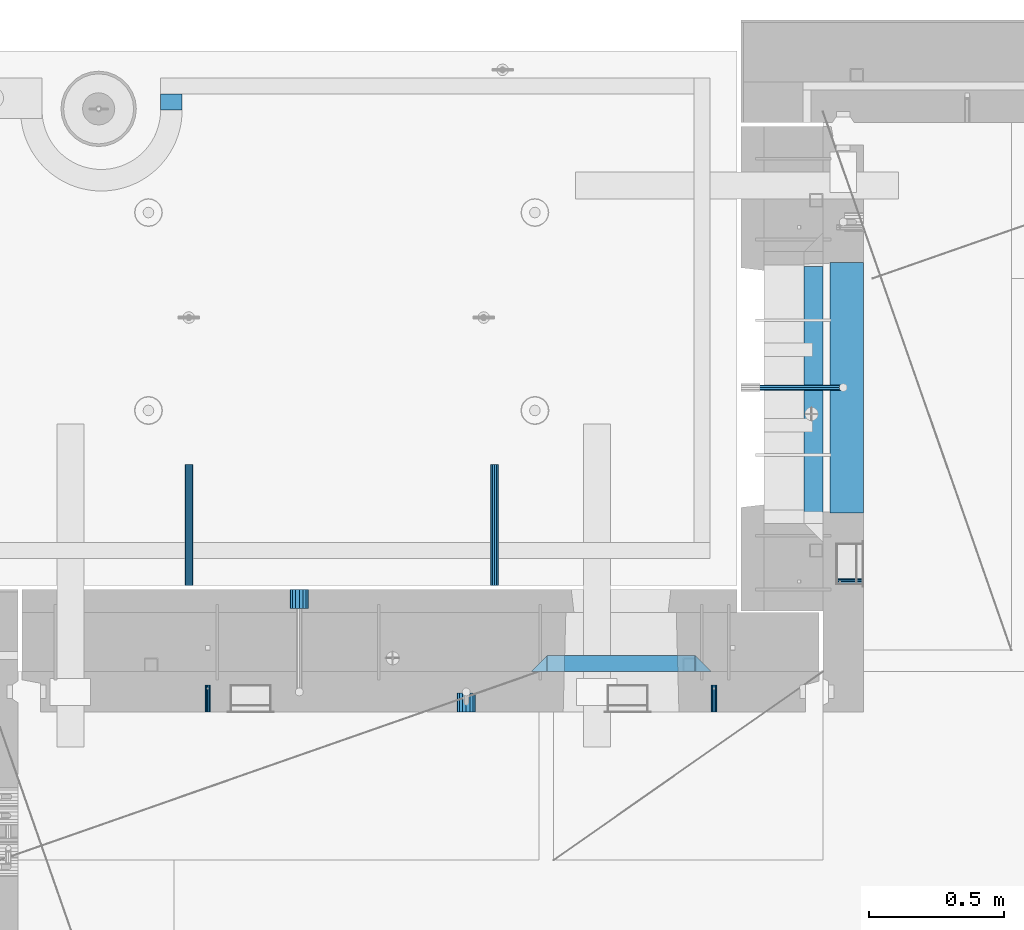
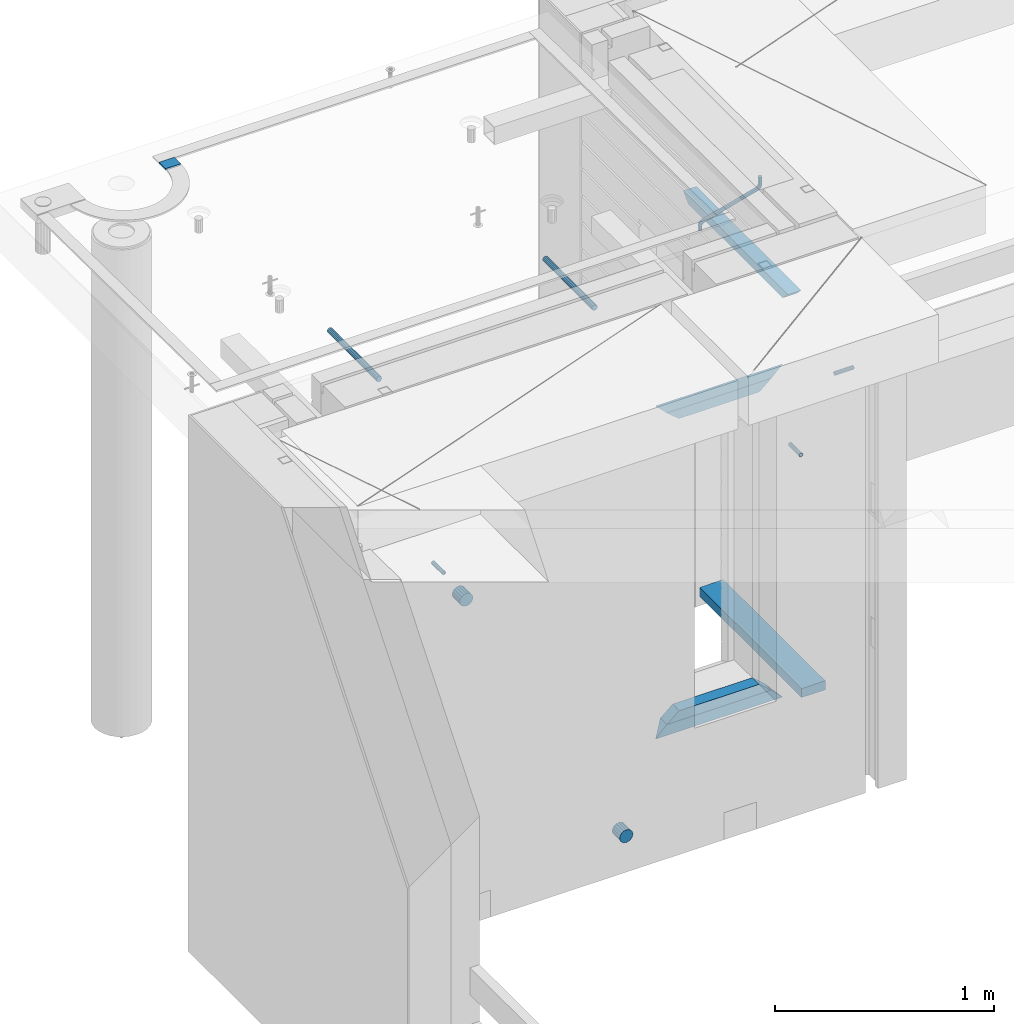
# One storey, part 157 of 349: 15 beams, 8 elements without a shape of their own.
"""IFC2X3 building model written with IfcOpenShell, lengths in millimetres."""

import ifcopenshell
import ifcopenshell.guid

model = None  # the IFC model being written
_history = None  # IfcOwnerHistory: only IFC2X3 demands one
_inside = {}  # id of a spatial element -> (the spatial element, [elements in it])
_under = {}  # id of a project, library or spatial element -> (it, [spatial elements below it])
_declared = {}  # id of a project -> (the project, [libraries it declares])
_typed = {}  # id of a type object -> (the type object, [elements of that type])
_made_of = {}  # id of a material, layer set ... -> (it, [elements and type objects made of it])


def new_model(schema):
    """Start an empty IFC model of exactly this schema.

    Asked for "IFC4X3", IfcOpenShell would pick the latest addendum, in which some entities
    have other attributes; the version numbers below select the first issue.
    IFC2X3 requires an IfcOwnerHistory on every rooted entity: one is made here for all.
    """
    global model, _history
    if schema == "IFC4X3":
        model = ifcopenshell.file(schema_version=(4, 3, 0, 0))
    else:
        model = ifcopenshell.file(schema=schema)
    _inside.clear()
    _under.clear()
    _declared.clear()
    _typed.clear()
    _made_of.clear()
    _history = None
    if model.schema == "IFC2X3":
        org = make("IfcOrganization", Name="unknown")
        user = make(
            "IfcPersonAndOrganization",
            ThePerson=make("IfcPerson", FamilyName="unknown"),
            TheOrganization=org,
        )
        app = make(
            "IfcApplication",
            ApplicationDeveloper=org,
            Version="unknown",
            ApplicationFullName="unknown",
            ApplicationIdentifier="unknown",
        )
        _history = make(
            "IfcOwnerHistory",
            OwningUser=user,
            OwningApplication=app,
            ChangeAction="ADDED",
            CreationDate=0,
        )
    return model


def make(cls, **values):
    """One entity of the class cls with the attributes given. An attribute that is None is left unset."""
    return model.create_entity(
        cls, **{name: value for name, value in values.items() if value is not None}
    )


def rooted(cls, **values):
    """An entity with a GlobalId (a new one), such as an element, a storey or a relation."""
    return make(cls, GlobalId=ifcopenshell.guid.new(), OwnerHistory=_history, **values)


def si_unit(unit_type, name, prefix=None):
    """IfcSIUnit, for example si_unit("LENGTHUNIT", "METRE", prefix="MILLI")."""
    return make("IfcSIUnit", UnitType=unit_type, Prefix=prefix, Name=name)


def assignment(units):
    """IfcUnitAssignment: the units of a project."""
    return None if units is None else make("IfcUnitAssignment", Units=units)


def point(xyz):
    """IfcCartesianPoint."""
    return None if xyz is None else make("IfcCartesianPoint", Coordinates=xyz)


def direction(xyz):
    """IfcDirection."""
    return None if xyz is None else make("IfcDirection", DirectionRatios=xyz)


def frame(location, z_axis=None, x_axis=None):
    """IfcAxis2Placement3D, a coordinate frame: its origin and axes. An axis left out is left unset."""
    return make(
        "IfcAxis2Placement3D",
        Location=point(location),
        Axis=direction(z_axis),
        RefDirection=direction(x_axis),
    )


def origin_with_axes():
    """The frame at (0, 0, 0) with the z axis (0, 0, 1) and the x axis (1, 0, 0) written out."""
    return frame((0.0, 0.0, 0.0), z_axis=(0.0, 0.0, 1.0), x_axis=(1.0, 0.0, 0.0))


def place(relative_to, where):
    """IfcLocalPlacement: puts the frame where relative to a parent placement (None: the world)."""
    return make(
        "IfcLocalPlacement", PlacementRelTo=relative_to, RelativePlacement=where
    )


def context(
    kind, dimensions, precision=None, world=None, true_north=None, identifier=None
):
    """IfcGeometricRepresentationContext, for example the 3D "Model" context."""
    return make(
        "IfcGeometricRepresentationContext",
        ContextIdentifier=identifier,
        ContextType=kind,
        CoordinateSpaceDimension=dimensions,
        Precision=precision,
        WorldCoordinateSystem=world,
        TrueNorth=true_north,
    )


def subcontext(parent, identifier, kind, view, scale=None):
    """IfcGeometricRepresentationSubContext, for example "Body" below "Model"."""
    return make(
        "IfcGeometricRepresentationSubContext",
        ContextIdentifier=identifier,
        ContextType=kind,
        ParentContext=parent,
        TargetScale=scale,
        TargetView=view,
    )


def project(units=None, contexts=None):
    """IfcProject with its units and contexts."""
    return rooted(
        "IfcProject",
        Name="project",
        RepresentationContexts=contexts,
        UnitsInContext=assignment(units),
    )


def spatial(cls, under=None, at=None, **own):
    """A site, building, storey or space (cls), placed at a placement, below another one or the project."""
    s = rooted(cls, ObjectPlacement=at, **own)
    if under is not None:
        _under.setdefault(under.id(), (under, []))[1].append(s)
    return s


def faces_of(points, faces, orient=None, outer=None):
    """IfcFace entities. A face is a list of loops; a loop is a list of indices into points, from 0.

    orient and outer hold one flag for each loop. By default every Orientation is true, the
    first loop of a face is its IfcFaceOuterBound and the others are IfcFaceBound.
    """
    made = []
    for i, loops in enumerate(faces):
        bounds = []
        for j, loop in enumerate(loops):
            is_outer = j == 0 if outer is None else outer[i][j]
            bounds.append(
                make(
                    "IfcFaceOuterBound" if is_outer else "IfcFaceBound",
                    Bound=make("IfcPolyLoop", Polygon=[points[k] for k in loop]),
                    Orientation=True if orient is None else orient[i][j],
                )
            )
        made.append(make("IfcFace", Bounds=bounds))
    return made


def faceted_brep(points, faces, orient=None, outer=None, voids=None):
    """IfcFacetedBrep: a solid bounded by flat faces; with voids (closed shells), ...WithVoids."""
    shared = [point(p) for p in points]
    hull = make("IfcClosedShell", CfsFaces=faces_of(shared, faces, orient, outer))
    if voids is None:
        return make("IfcFacetedBrep", Outer=hull)
    return make(
        "IfcFacetedBrepWithVoids",
        Outer=hull,
        Voids=[
            make(cls, CfsFaces=faces_of(shared, fs, o, b)) for cls, fs, o, b in voids
        ],
    )


def shape(context_of_items, identifier, shape_type, items):
    """IfcShapeRepresentation: the items that make up one representation, for example the "Body"."""
    return make(
        "IfcShapeRepresentation",
        ContextOfItems=context_of_items,
        RepresentationIdentifier=identifier,
        RepresentationType=shape_type,
        Items=items,
    )


def material(Name=None, Category=None):
    """IfcMaterial."""
    return make("IfcMaterial", Name=Name, Category=Category)


def made_of(thing, what):
    """Note that an element or type object is made of a material, layer set ...; save() writes the relation."""
    if what is not None:
        _made_of.setdefault(what.id(), (what, []))[1].append(thing)
    return thing


def type_object(cls, material=None, **own):
    """A type object (cls), such as IfcWallType, which elements share."""
    return made_of(rooted(cls, **own), material)


def element(
    cls,
    number,
    at=None,
    inside=None,
    cuts=None,
    type_object=None,
    material=None,
    context=None,
    identifier="Body",
    shape_type=None,
    held_by="IfcProductDefinitionShape",
    body=None,
    shapes=None,
    **own,
):
    """One element of the class cls, such as IfcWall. Its Tag is "e" and its number.

    at: its placement. inside: the storey or other place that contains it. cuts: it is an
    opening in that element (IfcRelVoidsElement). A single representation is given by context,
    identifier, shape_type and body (its items); several are given by shapes. held_by: the class
    of the entity that holds the representations. save() writes the other relations.
    """
    e = rooted(cls, Tag="e%d" % number, ObjectPlacement=at, **own)
    if body is not None:
        shapes = [shape(context, identifier, shape_type, body)]
    if shapes is not None:
        e.Representation = make(held_by, Representations=shapes)
    if inside is not None:
        _inside.setdefault(inside.id(), (inside, []))[1].append(e)
    if cuts is not None:
        rooted(
            "IfcRelVoidsElement", RelatingBuildingElement=cuts, RelatedOpeningElement=e
        )
    if type_object is not None:
        _typed.setdefault(type_object.id(), (type_object, []))[1].append(e)
    return made_of(e, material)


def aggregate(whole, parts):
    """IfcRelAggregates: a whole, such as a stair, and the parts it consists of."""
    return rooted("IfcRelAggregates", RelatingObject=whole, RelatedObjects=parts)


def save(model, path):
    """Write the relations noted so far, then the file.

    IfcRelAggregates (storeys below a building ...), IfcRelContainedInSpatialStructure (elements
    in a storey), IfcRelDefinesByType, IfcRelAssociatesMaterial and IfcRelDeclares: one each for
    every whole, place, type object, material and project.
    """
    for whole, parts in _under.values():
        aggregate(whole, parts)
    for where, things in _inside.values():
        rooted(
            "IfcRelContainedInSpatialStructure",
            RelatedElements=things,
            RelatingStructure=where,
        )
    for kind, things in _typed.values():
        rooted("IfcRelDefinesByType", RelatedObjects=things, RelatingType=kind)
    for what, things in _made_of.values():
        rooted("IfcRelAssociatesMaterial", RelatedObjects=things, RelatingMaterial=what)
    for by, libraries in _declared.values():
        rooted("IfcRelDeclares", RelatingContext=by, RelatedDefinitions=libraries)
    model.write(path)


model = new_model("IFC2X3")

# Units and contexts
model_context = context("Model", 3, precision=1e-05, world=origin_with_axes())
body_context = subcontext(model_context, "Body", "Model", "MODEL_VIEW")
ifc_project = project(units=[si_unit("LENGTHUNIT", "METRE", prefix="MILLI"), si_unit("AREAUNIT", "SQUARE_METRE"), si_unit("VOLUMEUNIT", "CUBIC_METRE"), si_unit("MASSUNIT", "GRAM", prefix="KILO"), si_unit("TIMEUNIT", "SECOND"), si_unit("PLANEANGLEUNIT", "RADIAN"), si_unit("SOLIDANGLEUNIT", "STERADIAN"), si_unit("THERMODYNAMICTEMPERATUREUNIT", "DEGREE_CELSIUS"), si_unit("LUMINOUSINTENSITYUNIT", "LUMEN")], contexts=[model_context])

# Site, building, storey
site_placement = place(None, origin_with_axes())
site = spatial("IfcSite", under=ifc_project, at=site_placement, CompositionType="ELEMENT")
building_placement = place(site_placement, origin_with_axes())
building = spatial("IfcBuilding", under=site, at=building_placement, CompositionType="ELEMENT")
storey_placement = place(building_placement, origin_with_axes())
storey = spatial("IfcBuildingStorey", under=building, at=storey_placement, Name="4", CompositionType="ELEMENT", Elevation=0.0)

# Assembly, beam
assembly_1_placement = place(storey_placement, origin_with_axes())
assembly_1 = element("IfcElementAssembly", 1, at=assembly_1_placement, inside=storey, AssemblyPlace="NOTDEFINED", PredefinedType="REINFORCEMENT_UNIT")
ifc_material_1 = material(Name="CONCRETE/C25/30")
beam_type_1 = type_object("IfcBeamType", PredefinedType="NOTDEFINED")
beam_1_placement = place(assembly_1_placement, frame((10955.0, 22139.9998901814, 93080.0), z_axis=(0.0, 0.0, -1.0), x_axis=(0.0, -1.0, 0.0)))
beam_1 = element("IfcBeam", 2, at=beam_1_placement, type_object=beam_type_1, material=ifc_material_1, Name="SK", context=body_context, shape_type="Brep", body=[
    faceted_brep([(100.641025641038, 35.0, 20.6410256410309), (55.0, 35.0, -25.0), (55.0, -35.0, -25.0), (98.8461538461561, -35.0, 18.8461538461561), (966.153464684117, -35.0, 18.8461538461561), (964.358592889246, 35.0, 20.6410256410309), (1009.99961853027, 35.0, -25.0), (1009.99961853027, -35.0, -25.0)], [[[0, 1, 2, 3]], [[0, 3, 4, 5]], [[1, 0, 5, 6]], [[2, 1, 6, 7]], [[3, 2, 7, 4]], [[4, 7, 6, 5]]]),
])

# Assemblies, beams
assembly_2_placement = place(storey_placement, origin_with_axes())
assembly_2 = element("IfcElementAssembly", 3, at=assembly_2_placement, inside=storey, AssemblyPlace="NOTDEFINED", PredefinedType="REINFORCEMENT_UNIT")
assembly_3_placement = place(assembly_2_placement, origin_with_axes())
assembly_3 = element("IfcElementAssembly", 4, at=assembly_3_placement, Name="Steel Assembly", AssemblyPlace="NOTDEFINED", PredefinedType="RIGID_FRAME")
ifc_material_2 = material(Name="STEEL/Steel_Undefined")
beam_type_2 = type_object("IfcBeamType", PredefinedType="NOTDEFINED")
beam_2_placement = place(assembly_3_placement, frame((8704.99903261663, 20429.9951872276, 92755.0), z_axis=(1.0, 0.0, 0.0), x_axis=(0.0, 1.0, 0.0)))
beam_2 = element("IfcBeam", 5, at=beam_2_placement, type_object=beam_type_2, material=ifc_material_2, Name="M16", context=body_context, shape_type="Brep", body=[
    faceted_brep([(0.0, -8.49999999999272, -1.45519152283669e-11), (0.0, -7.36121593215648, 4.24999999998545), (100.000000000262, -7.36121593215648, 4.24999999998545), (100.000000000262, -8.49999999999272, -1.45519152283669e-11), (0.0, -4.24999999998545, 7.36121593216376), (100.000000000262, -4.24999999998545, 7.36121593216376), (0.0, 1.45519152283669e-11, 8.49999999998545), (100.000000000262, 1.45519152283669e-11, 8.49999999998545), (0.0, 4.25000000001455, 7.36121593216376), (100.000000000262, 4.25000000001455, 7.36121593216376), (0.0, 7.36121593217104, 4.24999999998545), (100.000000000262, 7.36121593217104, 4.24999999998545), (0.0, 8.50000000000728, 0.0), (100.000000000262, 8.50000000000728, 0.0), (0.0, 7.36121593217104, -4.25000000001455), (100.000000000262, 7.36121593217104, -4.25000000001455), (0.0, 4.25000000000728, -7.36121593219286), (100.000000000262, 4.25000000000728, -7.36121593219286), (0.0, 7.27595761418343e-12, -8.5), (100.000000000262, 7.27595761418343e-12, -8.5), (0.0, -4.24999999999272, -7.36121593217831), (100.000000000262, -4.24999999999272, -7.36121593217831), (0.0, -7.36121593215648, -4.25), (100.000000000262, -7.36121593215648, -4.25), (0.0, -10.4999999999927, -1.45519152283669e-11), (0.0, -9.09326673972828, -5.25000000001455), (100.000000000262, -9.09326673972828, -5.25000000001455), (100.000000000262, -10.4999999999927, -1.45519152283669e-11), (0.0, -5.24999999998545, -9.09326673974283), (100.000000000262, -5.24999999998545, -9.09326673974283), (0.0, 7.27595761418343e-12, -10.5), (100.000000000262, 7.27595761418343e-12, -10.5), (0.0, 5.25000000001455, -9.09326673975738), (100.000000000262, 5.25000000001455, -9.09326673975738), (0.0, 9.09326673975011, -5.25000000001455), (100.000000000262, 9.09326673975011, -5.25000000001455), (0.0, 10.5000000000073, -1.45519152283669e-11), (100.000000000262, 10.5000000000073, -1.45519152283669e-11), (0.0, 9.09326673975011, 5.25), (100.000000000262, 9.09326673975011, 5.25), (0.0, 5.25000000000728, 9.09326673972828), (100.000000000262, 5.25000000000728, 9.09326673972828), (0.0, 1.45519152283669e-11, 10.4999999999854), (100.000000000262, 1.45519152283669e-11, 10.4999999999854), (0.0, -5.24999999999272, 9.09326673972828), (100.000000000262, -5.24999999999272, 9.09326673972828), (0.0, -9.09326673972828, 5.24999999998545), (100.000000000262, -9.09326673972828, 5.24999999998545)], [[[0, 1, 2, 3]], [[1, 4, 5, 2]], [[4, 6, 7, 5]], [[6, 8, 9, 7]], [[8, 10, 11, 9]], [[10, 12, 13, 11]], [[12, 14, 15, 13]], [[14, 16, 17, 15]], [[16, 18, 19, 17]], [[18, 20, 21, 19]], [[20, 22, 23, 21]], [[22, 0, 3, 23]], [[24, 25, 26, 27]], [[25, 28, 29, 26]], [[28, 30, 31, 29]], [[30, 32, 33, 31]], [[32, 34, 35, 33]], [[34, 36, 37, 35]], [[36, 38, 39, 37]], [[38, 40, 41, 39]], [[40, 42, 43, 41]], [[42, 44, 45, 43]], [[44, 46, 47, 45]], [[46, 24, 27, 47]], [[29, 31, 33, 35, 37, 39, 41, 43, 45, 47, 27, 26], [5, 7, 9, 11, 13, 15, 17, 19, 21, 23, 3, 2]], [[46, 44, 42, 40, 38, 36, 34, 32, 30, 28, 25, 24], [22, 20, 18, 16, 14, 12, 10, 8, 6, 4, 1, 0]]]),
])
aggregate(assembly_3, [beam_2])
assembly_4_placement = place(assembly_2_placement, origin_with_axes())
assembly_4 = element("IfcElementAssembly", 6, at=assembly_4_placement, Name="Steel Assembly", AssemblyPlace="NOTDEFINED", PredefinedType="RIGID_FRAME")
beam_3_placement = place(assembly_4_placement, frame((10584.9990326166, 20429.9951872276, 92755.0), z_axis=(1.0, 0.0, 0.0), x_axis=(0.0, 1.0, 0.0)))
beam_3 = element("IfcBeam", 7, at=beam_3_placement, type_object=beam_type_2, material=ifc_material_2, Name="M16", context=body_context, shape_type="Brep", body=[
    faceted_brep([(0.0, -8.49999999999272, -1.45519152283669e-11), (0.0, -7.36121593215648, 4.24999999998545), (100.000000000262, -7.36121593215648, 4.24999999998545), (100.000000000262, -8.49999999999272, -1.45519152283669e-11), (0.0, -4.24999999998545, 7.36121593216376), (100.000000000262, -4.24999999998545, 7.36121593216376), (0.0, 1.45519152283669e-11, 8.49999999998545), (100.000000000262, 1.45519152283669e-11, 8.49999999998545), (0.0, 4.25000000001455, 7.36121593216376), (100.000000000262, 4.25000000001455, 7.36121593216376), (0.0, 7.36121593217104, 4.24999999998545), (100.000000000262, 7.36121593217104, 4.24999999998545), (0.0, 8.50000000000728, 0.0), (100.000000000262, 8.50000000000728, 0.0), (0.0, 7.36121593217104, -4.25000000001455), (100.000000000262, 7.36121593217104, -4.25000000001455), (0.0, 4.25000000000728, -7.36121593219286), (100.000000000262, 4.25000000000728, -7.36121593219286), (0.0, 7.27595761418343e-12, -8.5), (100.000000000262, 7.27595761418343e-12, -8.5), (0.0, -4.24999999999272, -7.36121593217831), (100.000000000262, -4.24999999999272, -7.36121593217831), (0.0, -7.36121593215648, -4.25), (100.000000000262, -7.36121593215648, -4.25), (0.0, -10.4999999999927, -1.45519152283669e-11), (0.0, -9.09326673972828, -5.25000000001455), (100.000000000262, -9.09326673972828, -5.25000000001455), (100.000000000262, -10.4999999999927, -1.45519152283669e-11), (0.0, -5.24999999998545, -9.09326673974283), (100.000000000262, -5.24999999998545, -9.09326673974283), (0.0, 7.27595761418343e-12, -10.5), (100.000000000262, 7.27595761418343e-12, -10.5), (0.0, 5.25000000001455, -9.09326673975738), (100.000000000262, 5.25000000001455, -9.09326673975738), (0.0, 9.09326673975011, -5.25000000001455), (100.000000000262, 9.09326673975011, -5.25000000001455), (0.0, 10.5000000000073, -1.45519152283669e-11), (100.000000000262, 10.5000000000073, -1.45519152283669e-11), (0.0, 9.09326673975011, 5.25), (100.000000000262, 9.09326673975011, 5.25), (0.0, 5.25000000000728, 9.09326673972828), (100.000000000262, 5.25000000000728, 9.09326673972828), (0.0, 1.45519152283669e-11, 10.4999999999854), (100.000000000262, 1.45519152283669e-11, 10.4999999999854), (0.0, -5.24999999999272, 9.09326673972828), (100.000000000262, -5.24999999999272, 9.09326673972828), (0.0, -9.09326673972828, 5.24999999998545), (100.000000000262, -9.09326673972828, 5.24999999998545)], [[[0, 1, 2, 3]], [[1, 4, 5, 2]], [[4, 6, 7, 5]], [[6, 8, 9, 7]], [[8, 10, 11, 9]], [[10, 12, 13, 11]], [[12, 14, 15, 13]], [[14, 16, 17, 15]], [[16, 18, 19, 17]], [[18, 20, 21, 19]], [[20, 22, 23, 21]], [[22, 0, 3, 23]], [[24, 25, 26, 27]], [[25, 28, 29, 26]], [[28, 30, 31, 29]], [[30, 32, 33, 31]], [[32, 34, 35, 33]], [[34, 36, 37, 35]], [[36, 38, 39, 37]], [[38, 40, 41, 39]], [[40, 42, 43, 41]], [[42, 44, 45, 43]], [[44, 46, 47, 45]], [[46, 24, 27, 47]], [[29, 31, 33, 35, 37, 39, 41, 43, 45, 47, 27, 26], [5, 7, 9, 11, 13, 15, 17, 19, 21, 23, 3, 2]], [[46, 44, 42, 40, 38, 36, 34, 32, 30, 28, 25, 24], [22, 20, 18, 16, 14, 12, 10, 8, 6, 4, 1, 0]]]),
])
aggregate(assembly_4, [beam_3])

# Assembly, beam
assembly_5_placement = place(assembly_1_placement, origin_with_axes())
assembly_5 = element("IfcElementAssembly", 8, at=assembly_5_placement, Name="Steel Assembly", AssemblyPlace="NOTDEFINED", PredefinedType="RIGID_FRAME")
beam_4_placement = place(assembly_5_placement, frame((11140.0, 20914.9954408996, 92755.0), z_axis=(0.0, -1.0, 0.0), x_axis=(-1.0, 3.00000001838171e-08, 0.0)))
beam_4 = element("IfcBeam", 9, at=beam_4_placement, type_object=beam_type_2, material=ifc_material_2, Name="M16", context=body_context, shape_type="Brep", body=[
    faceted_brep([(0.0, -8.49999999999272, -1.45519152283669e-11), (0.0, -7.36121593215648, 4.24999999998545), (100.000000000262, -7.36121593215648, 4.24999999998545), (100.000000000262, -8.49999999999272, -1.45519152283669e-11), (0.0, -4.24999999998545, 7.36121593216376), (100.000000000262, -4.24999999998545, 7.36121593216376), (0.0, 1.45519152283669e-11, 8.49999999998545), (100.000000000262, 1.45519152283669e-11, 8.49999999998545), (0.0, 4.25000000001455, 7.36121593216376), (100.000000000262, 4.25000000001455, 7.36121593216376), (0.0, 7.36121593217104, 4.24999999998545), (100.000000000262, 7.36121593217104, 4.24999999998545), (0.0, 8.50000000000728, 0.0), (100.000000000262, 8.50000000000728, 0.0), (0.0, 7.36121593217104, -4.25000000001455), (100.000000000262, 7.36121593217104, -4.25000000001455), (0.0, 4.25000000000728, -7.36121593219286), (100.000000000262, 4.25000000000728, -7.36121593219286), (0.0, 7.27595761418343e-12, -8.5), (100.000000000262, 7.27595761418343e-12, -8.5), (0.0, -4.24999999999272, -7.36121593217831), (100.000000000262, -4.24999999999272, -7.36121593217831), (0.0, -7.36121593215648, -4.25), (100.000000000262, -7.36121593215648, -4.25), (0.0, -10.4999999999927, -1.45519152283669e-11), (0.0, -9.09326673972828, -5.25000000001455), (100.000000000262, -9.09326673972828, -5.25000000001455), (100.000000000262, -10.4999999999927, -1.45519152283669e-11), (0.0, -5.24999999998545, -9.09326673974283), (100.000000000262, -5.24999999998545, -9.09326673974283), (0.0, 7.27595761418343e-12, -10.5), (100.000000000262, 7.27595761418343e-12, -10.5), (0.0, 5.25000000001455, -9.09326673975738), (100.000000000262, 5.25000000001455, -9.09326673975738), (0.0, 9.09326673975011, -5.25000000001455), (100.000000000262, 9.09326673975011, -5.25000000001455), (0.0, 10.5000000000073, -1.45519152283669e-11), (100.000000000262, 10.5000000000073, -1.45519152283669e-11), (0.0, 9.09326673975011, 5.25), (100.000000000262, 9.09326673975011, 5.25), (0.0, 5.25000000000728, 9.09326673972828), (100.000000000262, 5.25000000000728, 9.09326673972828), (0.0, 1.45519152283669e-11, 10.4999999999854), (100.000000000262, 1.45519152283669e-11, 10.4999999999854), (0.0, -5.24999999999272, 9.09326673972828), (100.000000000262, -5.24999999999272, 9.09326673972828), (0.0, -9.09326673972828, 5.24999999998545), (100.000000000262, -9.09326673972828, 5.24999999998545)], [[[0, 1, 2, 3]], [[1, 4, 5, 2]], [[4, 6, 7, 5]], [[6, 8, 9, 7]], [[8, 10, 11, 9]], [[10, 12, 13, 11]], [[12, 14, 15, 13]], [[14, 16, 17, 15]], [[16, 18, 19, 17]], [[18, 20, 21, 19]], [[20, 22, 23, 21]], [[22, 0, 3, 23]], [[24, 25, 26, 27]], [[25, 28, 29, 26]], [[28, 30, 31, 29]], [[30, 32, 33, 31]], [[32, 34, 35, 33]], [[34, 36, 37, 35]], [[36, 38, 39, 37]], [[38, 40, 41, 39]], [[40, 42, 43, 41]], [[42, 44, 45, 43]], [[44, 46, 47, 45]], [[46, 24, 27, 47]], [[29, 31, 33, 35, 37, 39, 41, 43, 45, 47, 27, 26], [5, 7, 9, 11, 13, 15, 17, 19, 21, 23, 3, 2]], [[46, 44, 42, 40, 38, 36, 34, 32, 30, 28, 25, 24], [22, 20, 18, 16, 14, 12, 10, 8, 6, 4, 1, 0]]]),
])
aggregate(assembly_5, [beam_4])

# Beam
ifc_material_3 = material()
beam_type_3 = type_object("IfcBeamType", Name="D20", PredefinedType="NOTDEFINED")
beam_5_placement = place(assembly_1_placement, frame((10747.93, 21634.9982799665, 93220.28), z_axis=(0.999209485784166, 0.00020572799995638, -0.0397537569914116), x_axis=(0.0397537569984931, -6.39999925638531e-08, 0.999209506962629)))
beam_5 = element("IfcBeam", 10, at=beam_5_placement, type_object=beam_type_3, material=ifc_material_3, Name="JM20", ObjectType="D20", context=body_context, shape_type="Brep", body=[
    faceted_brep([(0.0, -10.0, 0.0), (-4.19531716033816e-08, -7.07106781186667, -7.07106781187031), (26.3851730625611, -7.07106780271351, -7.07106779974674), (26.3851730660535, -9.99999999077045, 1.18243406177498e-08), (0.0, 0.0, -10.0), (26.3851730589668, 9.14587872102857e-09, -9.99999998788189), (4.196772351861e-08, 7.07106781186303, -7.07106781186667), (26.3851730576571, 7.07106782101255, -7.0710677997472), (0.0, 10.0, 0.0), (26.3851730593888, 10.0000000091495, 1.21176526590716e-08), (4.196772351861e-08, 7.07106781185939, 7.07106781185939), (26.3851730631723, 7.07106782101619, 7.07106782398387), (0.0, 0.0, 10.0), (26.3851730667375, 9.15315467864275e-09, 10.0000000121181), (-4.19531716033816e-08, -7.07106781187031, 7.07106781185939), (26.3851730680617, -7.07106780271351, 7.07106782398296), (38.6387990555377, 0.00053833780111745, -7.38336449283906), (37.4430586178205, -7.07058200552274, -4.70977034770021), (34.5550974405633, -9.99964106806146, 1.74460312923975), (31.6666440137633, -7.07083577596131, 8.19887149183023), (30.4697151806322, 0.000179452214069897, 10.8722118684241), (31.6654556183639, 7.07129979554884, 8.19861772327886), (34.5534167956066, 10.0003588580803, 1.74424424634026), (37.4418702223775, 7.07155356597286, -4.71002411625204), (46.5698109210789, 7.07292605872499, 1.96124086770624), (48.7548734831362, 0.00205940803425619, 0.0100898832683924), (41.2967727296491, 10.0013728005906, 6.67270684289633), (36.0246331664675, 7.07195524891722, 11.3845749391899), (33.8417400848848, 0.000686475628754124, 13.3366967298962), (36.0268026468402, -7.07018017507653, 11.385545745416), (41.2998408382991, -9.99862691692761, 6.67407977023777), (46.5719804015243, -7.06920936526149, 1.96221167398289), (52.1766955363273, 7.07494587836845, 11.77897587077), (54.9687243336812, 0.00429788071051007, 10.8906314292522), (45.4389138642146, 10.0028649622, 13.9256551011317), (38.7022804405424, 7.07291984242329, 16.0731735411446), (35.9130237601494, 0.00143263318750542, 16.9635440140905), (38.7050525575032, -7.06921536447044, 16.0751995724927), (45.4428342298197, -9.99713444846202, 13.9285203429881), (52.1794676532882, -7.06718932852891, 11.7810019021831), (142.166420299589, -7.00909836739083, 294.143799597011), (135.429786872017, -9.93904348683645, 296.291318034092), (144.955676979953, 0.0623888418631395, 293.253429124143), (142.163648182657, 7.13303683951744, 294.141773565681), (135.425866510661, 10.0609559233271, 296.288452795829), (128.689233087061, 7.13101080351771, 298.435971235634), (125.899976406712, 0.0595235942673753, 299.326341708503), (128.692005203993, -7.01112440339057, 298.437997266966), (147.068569920637, 0.0631443010061048, 296.926548661886), (144.897857494318, -7.00812174957537, 298.892215917644), (139.655137467547, -9.93753272500544, 303.636800386314), (134.411524128242, -7.00907940566321, 308.380988833921), (132.238655054738, 0.0617899707685865, 310.345700010335), (134.409367481101, 7.13305602133914, 308.38003275464), (139.652087507944, 10.0624669967765, 303.63544828606), (144.895700847192, 7.13401367743427, 298.891259838389), (149.349355837621, 7.13466950711154, 302.082919188319), (150.512901837996, 0.0636515012993186, 299.394888529177), (146.541460642286, 10.0634815017911, 308.572636332), (143.734043175544, 7.13442914049301, 315.062451673432), (142.571650514263, 0.0633115715718304, 317.750719402909), (143.735196514695, -7.0077064342513, 315.062688743805), (146.543091710148, -9.93651842893087, 308.572971600169), (149.350509176773, -7.0074660676255, 302.083156258706), (154.724909358454, 7.13488656737172, 303.143653317829), (154.670204234542, 0.063819369621342, 300.215230568659), (154.856921558763, 10.0638172729959, 310.213489346082), (154.988909878753, 7.13488360238989, 317.283324591871), (155.043557350815, 0.0638151764978829, 320.211745451903), (154.988852227005, -7.00725202125614, 317.28332270274), (154.856840031658, -9.93618272723688, 310.213486674455), (154.724851706691, -7.00724905626703, 303.143651428684), (199.544700311235, -7.00743165723543, 302.30682413155), (199.676688632229, -9.93636532781238, 309.37665937721), (199.490052838737, 0.0636367686238373, 299.378403271518), (199.544757962984, 7.13470396637786, 302.306826020583), (199.676770164122, 10.0636346720203, 309.376662048705), (199.808758485131, 7.13470100144696, 316.446497294365), (199.863405957614, 0.0636325755804137, 319.374918154397), (199.808700833368, -7.00743462216269, 316.446495405334)], [[[0, 1, 2, 3]], [[1, 4, 5, 2]], [[4, 6, 7, 5]], [[6, 8, 9, 7]], [[8, 10, 11, 9]], [[10, 12, 13, 11]], [[12, 14, 15, 13]], [[14, 0, 3, 15]], [[14, 12, 10, 8, 6, 4, 1, 0]], [[2, 5, 16, 17]], [[3, 2, 17, 18]], [[15, 3, 18, 19]], [[13, 15, 19, 20]], [[11, 13, 20, 21]], [[9, 11, 21, 22]], [[7, 9, 22, 23]], [[5, 7, 23, 16]], [[23, 24, 25, 16]], [[22, 26, 24, 23]], [[21, 27, 26, 22]], [[20, 28, 27, 21]], [[19, 29, 28, 20]], [[18, 30, 29, 19]], [[17, 31, 30, 18]], [[16, 25, 31, 17]], [[24, 32, 33, 25]], [[26, 34, 32, 24]], [[27, 35, 34, 26]], [[28, 36, 35, 27]], [[29, 37, 36, 28]], [[30, 38, 37, 29]], [[31, 39, 38, 30]], [[25, 33, 39, 31]], [[38, 39, 40, 41]], [[39, 33, 42, 40]], [[33, 32, 43, 42]], [[32, 34, 44, 43]], [[34, 35, 45, 44]], [[35, 36, 46, 45]], [[36, 37, 47, 46]], [[37, 38, 41, 47]], [[40, 42, 48, 49]], [[41, 40, 49, 50]], [[47, 41, 50, 51]], [[46, 47, 51, 52]], [[45, 46, 52, 53]], [[44, 45, 53, 54]], [[43, 44, 54, 55]], [[42, 43, 55, 48]], [[55, 56, 57, 48]], [[54, 58, 56, 55]], [[53, 59, 58, 54]], [[52, 60, 59, 53]], [[51, 61, 60, 52]], [[50, 62, 61, 51]], [[49, 63, 62, 50]], [[48, 57, 63, 49]], [[56, 64, 65, 57]], [[58, 66, 64, 56]], [[59, 67, 66, 58]], [[60, 68, 67, 59]], [[61, 69, 68, 60]], [[62, 70, 69, 61]], [[63, 71, 70, 62]], [[57, 65, 71, 63]], [[70, 71, 72, 73]], [[71, 65, 74, 72]], [[65, 64, 75, 74]], [[64, 66, 76, 75]], [[66, 67, 77, 76]], [[67, 68, 78, 77]], [[68, 69, 79, 78]], [[69, 70, 73, 79]], [[74, 75, 76, 77, 78, 79, 73, 72]]]),
])

beam_type_4 = type_object("IfcBeamType", Name="D70", PredefinedType="NOTDEFINED")
beam_6_placement = place(assembly_2_placement, frame((9665.00172002957, 20429.9951872276, 90955.0), z_axis=(0.0, 0.0, 1.0), x_axis=(0.0, 1.0, 0.0)))
beam_6 = element("IfcBeam", 11, at=beam_6_placement, type_object=beam_type_4, material=ifc_material_3, ObjectType="D70", context=body_context, shape_type="Brep", body=[
    faceted_brep([(0.0, -35.0, 0.0), (0.0, -32.3357836378964, -13.3939201327739), (70.0, -32.3357836378964, -13.3939201327739), (70.0, -35.0, 0.0), (0.0, -24.7487373415279, -24.7487373415352), (70.0, -24.7487373415279, -24.7487373415352), (0.0, -13.3939201327776, -32.3357836379), (70.0, -13.3939201327776, -32.3357836379), (0.0, 0.0, -35.0), (70.0, 0.0, -35.0), (0.0, 13.3939201327776, -32.3357836379), (70.0, 13.3939201327776, -32.3357836379), (0.0, 24.7487373415279, -24.7487373415352), (70.0, 24.7487373415279, -24.7487373415352), (0.0, 32.3357836378964, -13.3939201327739), (70.0, 32.3357836378964, -13.3939201327739), (0.0, 35.0, 0.0), (70.0, 35.0, 0.0), (0.0, 32.3357836378964, 13.3939201327739), (70.0, 32.3357836378964, 13.3939201327739), (0.0, 24.7487373415279, 24.7487373415352), (70.0, 24.7487373415279, 24.7487373415352), (0.0, 13.3939201327776, 32.3357836379), (70.0, 13.3939201327776, 32.3357836379), (0.0, 0.0, 35.0), (70.0, 0.0, 35.0), (0.0, -13.3939201327776, 32.3357836379), (70.0, -13.3939201327776, 32.3357836379), (0.0, -24.7487373415279, 24.7487373415352), (70.0, -24.7487373415279, 24.7487373415352), (0.0, -32.3357836378964, 13.3939201327739), (70.0, -32.3357836378964, 13.3939201327739)], [[[0, 1, 2, 3]], [[1, 4, 5, 2]], [[4, 6, 7, 5]], [[6, 8, 9, 7]], [[8, 10, 11, 9]], [[10, 12, 13, 11]], [[12, 14, 15, 13]], [[14, 16, 17, 15]], [[16, 18, 19, 17]], [[18, 20, 21, 19]], [[20, 22, 23, 21]], [[22, 24, 25, 23]], [[24, 26, 27, 25]], [[26, 28, 29, 27]], [[28, 30, 31, 29]], [[30, 0, 3, 31]], [[5, 7, 9, 11, 13, 15, 17, 19, 21, 23, 25, 27, 29, 31, 3, 2]], [[30, 28, 26, 24, 22, 20, 18, 16, 14, 12, 10, 8, 6, 4, 1, 0]]]),
])

beam_7_placement = place(assembly_2_placement, frame((9044.99633327303, 20884.9951872276, 92255.0), z_axis=(0.0, 0.0, 1.0), x_axis=(0.0, -1.0, 0.0)))
beam_7 = element("IfcBeam", 12, at=beam_7_placement, type_object=beam_type_4, material=ifc_material_3, ObjectType="D70", context=body_context, shape_type="Brep", body=[
    faceted_brep([(0.0, -35.0, 0.0), (0.0, -32.3357836378964, -13.3939201327739), (70.0, -32.3357836378964, -13.3939201327739), (70.0, -35.0, 0.0), (0.0, -24.7487373415279, -24.7487373415352), (70.0, -24.7487373415279, -24.7487373415352), (0.0, -13.3939201327776, -32.3357836379), (70.0, -13.3939201327776, -32.3357836379), (0.0, 0.0, -35.0), (70.0, 0.0, -35.0), (0.0, 13.3939201327776, -32.3357836379), (70.0, 13.3939201327776, -32.3357836379), (0.0, 24.7487373415279, -24.7487373415352), (70.0, 24.7487373415279, -24.7487373415352), (0.0, 32.3357836378964, -13.3939201327739), (70.0, 32.3357836378964, -13.3939201327739), (0.0, 35.0, 0.0), (70.0, 35.0, 0.0), (0.0, 32.3357836378964, 13.3939201327739), (70.0, 32.3357836378964, 13.3939201327739), (0.0, 24.7487373415279, 24.7487373415352), (70.0, 24.7487373415279, 24.7487373415352), (0.0, 13.3939201327776, 32.3357836379), (70.0, 13.3939201327776, 32.3357836379), (0.0, 0.0, 35.0), (70.0, 0.0, 35.0), (0.0, -13.3939201327776, 32.3357836379), (70.0, -13.3939201327776, 32.3357836379), (0.0, -24.7487373415279, 24.7487373415352), (70.0, -24.7487373415279, 24.7487373415352), (0.0, -32.3357836378964, 13.3939201327739), (70.0, -32.3357836378964, 13.3939201327739)], [[[0, 1, 2, 3]], [[1, 4, 5, 2]], [[4, 6, 7, 5]], [[6, 8, 9, 7]], [[8, 10, 11, 9]], [[10, 12, 13, 11]], [[12, 14, 15, 13]], [[14, 16, 17, 15]], [[16, 18, 19, 17]], [[18, 20, 21, 19]], [[20, 22, 23, 21]], [[22, 24, 25, 23]], [[24, 26, 27, 25]], [[26, 28, 29, 27]], [[28, 30, 31, 29]], [[30, 0, 3, 31]], [[5, 7, 9, 11, 13, 15, 17, 19, 21, 23, 25, 27, 29, 31, 3, 2]], [[30, 28, 26, 24, 22, 20, 18, 16, 14, 12, 10, 8, 6, 4, 1, 0]]]),
])

ifc_material_4 = material(Name="TIMBER/PUU")
beam_type_5 = type_object("IfcBeamType", PredefinedType="NOTDEFINED")
beam_8_placement = place(assembly_1_placement, frame((11077.5, 21169.9999618525, 90830.0), z_axis=(0.0, 0.0, 1.0), x_axis=(0.0, 1.0, 0.0)))
beam_8 = element("IfcBeam", 13, at=beam_8_placement, type_object=beam_type_5, material=ifc_material_4, context=body_context, shape_type="Brep", body=[
    faceted_brep([(0.0, 62.5, -25.0), (0.0, 62.5, 25.0), (930.0, 62.5, 25.0), (930.0, 62.5, -25.0), (0.0, -62.5, 25.0), (930.0, -62.5, 25.0), (0.0, -62.5, -25.0), (930.0, -62.5, -25.0)], [[[0, 1, 2, 3]], [[1, 4, 5, 2]], [[4, 6, 7, 5]], [[6, 0, 3, 7]], [[5, 7, 3, 2]], [[6, 4, 1, 0]]]),
])

aggregate(assembly_1, [beam_5, assembly_5, beam_8, beam_1])

# Assemblies, beams
assembly_6_placement = place(storey_placement, origin_with_axes())
assembly_6 = element("IfcElementAssembly", 14, at=assembly_6_placement, inside=storey, AssemblyPlace="NOTDEFINED", PredefinedType="REINFORCEMENT_UNIT")
assembly_7_placement = place(assembly_6_placement, origin_with_axes())
assembly_7 = element("IfcElementAssembly", 15, at=assembly_7_placement, Name="Steel Assembly", AssemblyPlace="NOTDEFINED", PredefinedType="RIGID_FRAME")
ifc_material_5 = material(Name="STEEL/S235JR")
beam_type_6 = type_object("IfcBeamType", Name="D30", PredefinedType="NOTDEFINED")
beam_9_placement = place(assembly_7_placement, frame((8634.99985675633, 20900.0253394533, 93575.0), z_axis=(0.0, 0.0, 1.0), x_axis=(0.0, 1.0, 0.0)))
beam_9 = element("IfcBeam", 16, at=beam_9_placement, type_object=beam_type_6, material=ifc_material_5, Name="Rd30", ObjectType="D30", context=body_context, shape_type="Brep", body=[
    faceted_brep([(0.0, -15.0, 0.0), (0.0, -12.9903810567666, -7.5), (450.0, -12.9903810567666, -7.5), (450.0, -15.0, 0.0), (0.0, -7.5, -12.9903810567666), (450.0, -7.5, -12.990381056763), (0.0, 0.0, -15.0), (450.0, 0.0, -15.0), (0.0, 7.5, -12.9903810567666), (450.0, 7.5, -12.990381056763), (0.0, 12.9903810567666, -7.5), (450.0, 12.9903810567666, -7.5), (0.0, 15.0, 0.0), (450.0, 15.0, 0.0), (0.0, 12.9903810567666, 7.5), (450.0, 12.9903810567666, 7.5), (0.0, 7.5, 12.9903810567666), (450.0, 7.5, 12.990381056763), (0.0, 0.0, 15.0), (450.0, 0.0, 15.0), (0.0, -7.5, 12.9903810567666), (450.0, -7.5, 12.990381056763), (0.0, -12.9903810567666, 7.5), (450.0, -12.9903810567666, 7.5)], [[[0, 1, 2, 3]], [[1, 4, 5, 2]], [[4, 6, 7, 5]], [[6, 8, 9, 7]], [[8, 10, 11, 9]], [[10, 12, 13, 11]], [[12, 14, 15, 13]], [[14, 16, 17, 15]], [[16, 18, 19, 17]], [[18, 20, 21, 19]], [[20, 22, 23, 21]], [[22, 0, 3, 23]], [[5, 7, 9, 11, 13, 15, 17, 19, 21, 23, 3, 2]], [[22, 20, 18, 16, 14, 12, 10, 8, 6, 4, 1, 0]]]),
])
aggregate(assembly_7, [beam_9])
assembly_8_placement = place(assembly_6_placement, origin_with_axes())
assembly_8 = element("IfcElementAssembly", 17, at=assembly_8_placement, Name="Steel Assembly", AssemblyPlace="NOTDEFINED", PredefinedType="RIGID_FRAME")
beam_10_placement = place(assembly_8_placement, frame((9769.99985700661, 20900.0152136098, 93575.0), z_axis=(0.0, 0.0, 1.0), x_axis=(0.0, 1.0, 0.0)))
beam_10 = element("IfcBeam", 18, at=beam_10_placement, type_object=beam_type_6, material=ifc_material_5, Name="Rd30", ObjectType="D30", context=body_context, shape_type="Brep", body=[
    faceted_brep([(0.0, -15.0, 0.0), (0.0, -12.9903810567666, -7.5), (450.0, -12.9903810567666, -7.5), (450.0, -15.0, 0.0), (0.0, -7.5, -12.9903810567666), (450.0, -7.5, -12.990381056763), (0.0, 0.0, -15.0), (450.0, 0.0, -15.0), (0.0, 7.5, -12.9903810567666), (450.0, 7.5, -12.990381056763), (0.0, 12.9903810567666, -7.5), (450.0, 12.9903810567666, -7.5), (0.0, 15.0, 0.0), (450.0, 15.0, 0.0), (0.0, 12.9903810567666, 7.5), (450.0, 12.9903810567666, 7.5), (0.0, 7.5, 12.9903810567666), (450.0, 7.5, 12.990381056763), (0.0, 0.0, 15.0), (450.0, 0.0, 15.0), (0.0, -7.5, 12.9903810567666), (450.0, -7.5, 12.990381056763), (0.0, -12.9903810567666, 7.5), (450.0, -12.9903810567666, 7.5)], [[[0, 1, 2, 3]], [[1, 4, 5, 2]], [[4, 6, 7, 5]], [[6, 8, 9, 7]], [[8, 10, 11, 9]], [[10, 12, 13, 11]], [[12, 14, 15, 13]], [[14, 16, 17, 15]], [[16, 18, 19, 17]], [[18, 20, 21, 19]], [[20, 22, 23, 21]], [[22, 0, 3, 23]], [[5, 7, 9, 11, 13, 15, 17, 19, 21, 23, 3, 2]], [[22, 20, 18, 16, 14, 12, 10, 8, 6, 4, 1, 0]]]),
])
aggregate(assembly_8, [beam_10])

# Beam
beam_type_7 = type_object("IfcBeamType", PredefinedType="NOTDEFINED")
beam_11_placement = place(assembly_2_placement, frame((10575.0002360344, 20609.9951872276, 93145.0), z_axis=(0.0, 0.0, -1.0), x_axis=(-1.0, 3.00000001838171e-08, 0.0)))
beam_11 = element("IfcBeam", 19, at=beam_11_placement, type_object=beam_type_7, material=ifc_material_1, Name="SK", context=body_context, shape_type="Brep", body=[
    faceted_brep([(60.0000000000073, 30.0, 30.0), (0.0, -30.0, -30.0), (60.0000000000073, -30.0, 30.0), (610.001525878895, 30.0, 30.0), (670.001525878906, -30.0, -30.0), (610.001525878895, -30.0, 30.0)], [[[0, 1, 2]], [[1, 0, 3, 4]], [[2, 1, 4, 5]], [[0, 2, 5, 3]], [[5, 4, 3]]]),
])

beam_12_placement = place(assembly_2_placement, frame((10515.0002360344, 20609.9951872276, 93085.0), z_axis=(0.0, 0.0, -1.0), x_axis=(-1.0, 3.00000001838171e-08, 0.0)))
beam_12 = element("IfcBeam", 20, at=beam_12_placement, type_object=beam_type_7, material=ifc_material_1, Name="SK", context=body_context, shape_type="Brep", body=[
    faceted_brep([(0.0, -30.0, -30.0), (64.0555799329595, -30.0, 24.9047827876493), (65.6772015545812, 30.0, 26.2947441772849), (0.0, 30.0, -30.0), (64.0555799329595, -30.0, 24.0540540540533), (65.6772015545812, 30.0, 25.6756756756804), (485.947471824853, -30.0, 24.0540540540533), (484.325850203231, 30.0, 25.6756756756804), (484.325850203231, 30.0, 26.293436281092), (550.001525878906, 30.0, -30.0), (550.001525878906, -30.0, -30.0), (485.947471824853, -30.0, 24.9034748914273)], [[[0, 1, 2, 3]], [[4, 5, 2, 1]], [[6, 7, 5, 4]], [[3, 2, 5, 7, 8, 9]], [[0, 3, 9, 10]], [[6, 4, 1, 0, 10, 11]], [[7, 6, 11, 8]], [[8, 11, 10, 9]]]),
])

beam_13_placement = place(assembly_2_placement, frame((9904.99871015549, 20609.9951872276, 91350.0), z_axis=(0.0, 0.0, 1.0), x_axis=(1.0, 0.0, 0.0)))
beam_13 = element("IfcBeam", 21, at=beam_13_placement, type_object=beam_type_7, material=ifc_material_1, Name="SK", context=body_context, shape_type="Brep", body=[
    faceted_brep([(610.001525878895, -30.0, 30.0), (670.001525878906, -30.0, -30.0), (610.001525878895, 30.0, 30.0), (60.0000000000073, 30.0, 30.0), (60.0000000000073, -30.0, 30.0), (0.0, -30.0, -30.0)], [[[0, 1, 2]], [[3, 4, 0, 2]], [[4, 5, 1, 0]], [[5, 3, 2, 1]], [[3, 5, 4]]]),
])

beam_14_placement = place(assembly_2_placement, frame((9964.99871015549, 20609.9951872276, 91410.0), z_axis=(0.0, 0.0, 1.0), x_axis=(1.0, 0.0, 0.0)))
beam_14 = element("IfcBeam", 22, at=beam_14_placement, type_object=beam_type_7, material=ifc_material_1, Name="SK", context=body_context, shape_type="Brep", body=[
    faceted_brep([(550.001525878906, -30.0, -30.0), (550.001525878906, 30.0, -30.0), (484.324324324325, 30.0, 26.2947441772849), (485.945945945947, -30.0, 24.9047827876348), (484.324324324325, 30.0, 25.6756756756804), (485.945945945947, -30.0, 24.0540540540533), (65.6756756756768, 30.0, 25.6756756756804), (64.0540540540533, -30.0, 24.0540540540533), (65.6756756756768, 30.0, 26.293436281092), (64.0540540540533, -30.0, 24.9034748914419), (0.0, -30.0, -30.0), (0.0, 30.0, -30.0)], [[[0, 1, 2, 3]], [[4, 5, 3, 2]], [[5, 4, 6, 7]], [[7, 6, 8, 9]], [[0, 3, 5, 7, 9, 10]], [[10, 11, 1, 0]], [[6, 4, 2, 1, 11, 8]], [[10, 9, 8, 11]]]),
])

aggregate(assembly_2, [assembly_3, assembly_4, beam_6, beam_7, beam_11, beam_12, beam_13, beam_14])

ifc_material_6 = material(Name="CONCRETE/Concrete_Undefined")
beam_type_8 = type_object("IfcBeamType", PredefinedType="NOTDEFINED")
beam_15_placement = place(assembly_6_placement, frame((8570.00544375128, 22665.0534145719, 93707.3590237257), z_axis=(1.00999999609277e-07, -0.00299573299934615, 0.999995512781826), x_axis=(-0.000187248000059734, 0.999995495250841, 0.0029957330006511)))
beam_15 = element("IfcBeam", 23, at=beam_15_placement, type_object=beam_type_8, material=ifc_material_6, context=body_context, shape_type="Brep", body=[
    faceted_brep([(1.34605215862393e-10, 40.0, -5.0), (-1.20053300634027e-10, 39.9999999999982, 4.99999999998545), (60.1825564420724, 39.9999999999982, 5.0), (60.182556442418, 40.0, -5.0), (-1.23691279441118e-10, -40.0000000000018, 4.9999999999709), (60.1825564420724, -40.0, 5.0), (1.30967237055302e-10, -40.0, -5.00000000001455), (60.182556442418, -39.9999999999982, -5.0)], [[[0, 1, 2, 3]], [[1, 4, 5, 2]], [[4, 6, 7, 5]], [[6, 0, 3, 7]], [[5, 7, 3, 2]], [[6, 4, 1, 0]]]),
])

aggregate(assembly_6, [assembly_7, assembly_8, beam_15])

save(model, "model.ifc")
